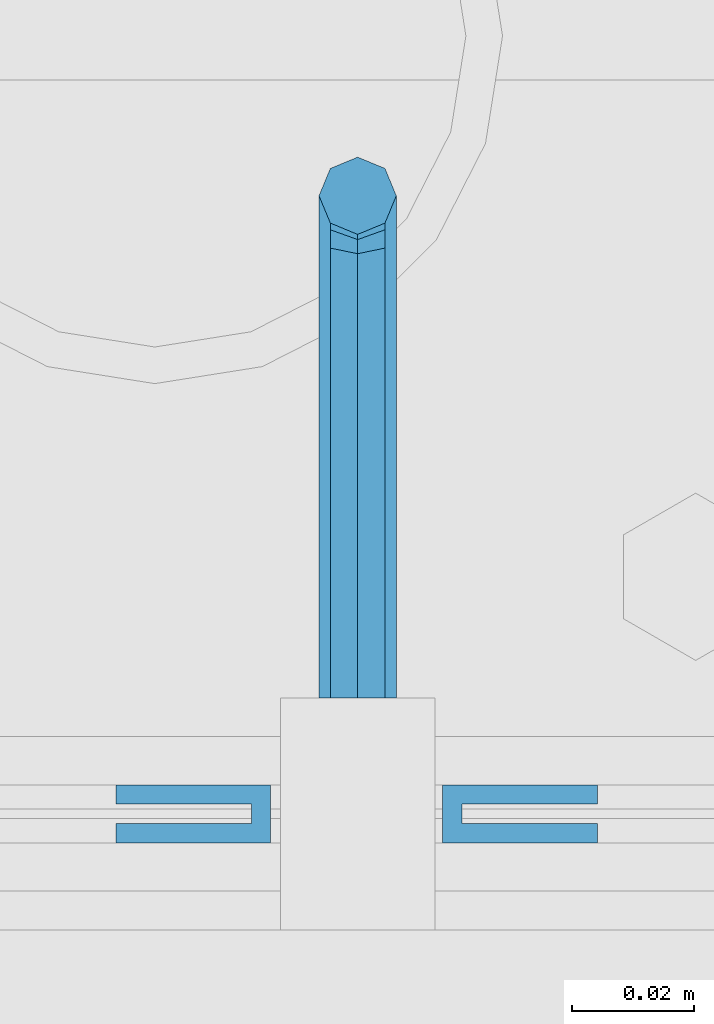
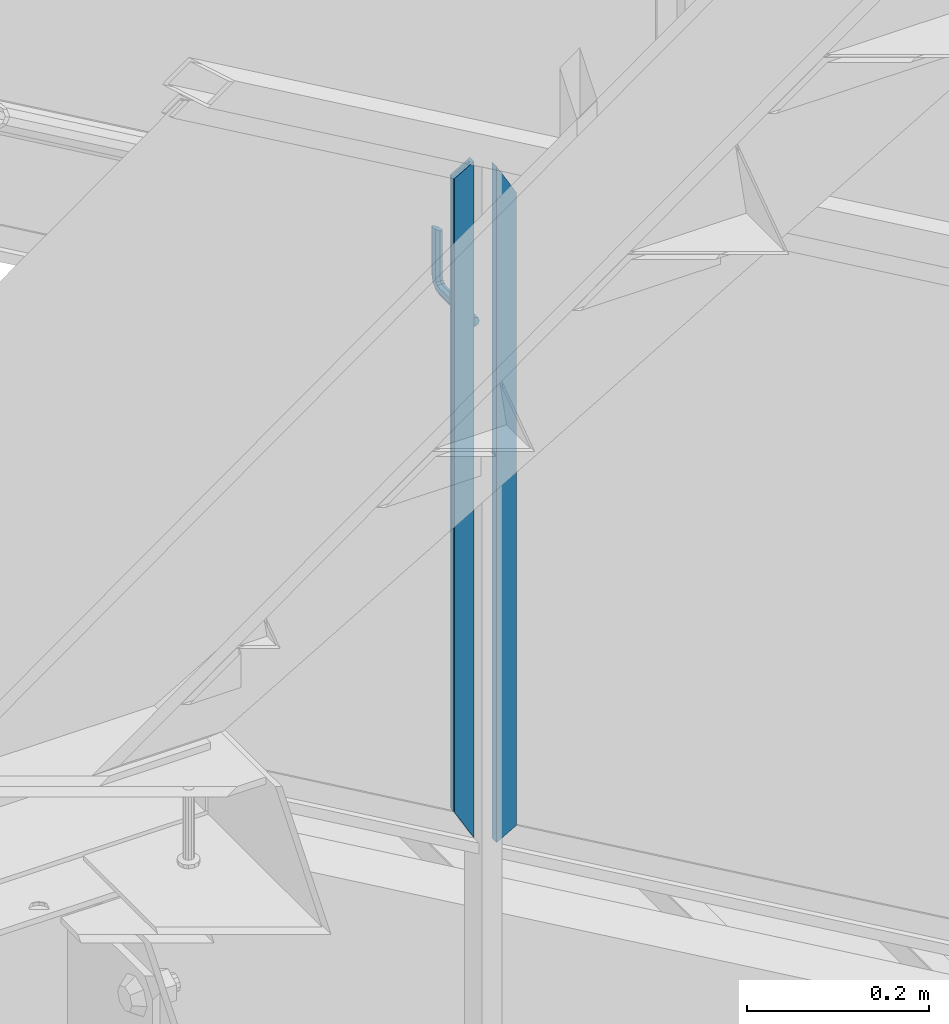
# One storey, part 932 of 1179: 3 beams, 1 element without a shape of its own.
"""IFC2X3 building model written with IfcOpenShell, lengths in millimetres."""

from ifc_helpers import new_model, si_unit, frame, origin_with_axes, place, context, subcontext, project, spatial, faceted_brep, material, type_object, element, aggregate, save


model = new_model("IFC2X3")

# Units and contexts
model_context = context("Model", 3, precision=1e-05, world=origin_with_axes())
body_context = subcontext(model_context, "Body", "Model", "MODEL_VIEW")
ifc_project = project(units=[si_unit("LENGTHUNIT", "METRE", prefix="MILLI"), si_unit("AREAUNIT", "SQUARE_METRE"), si_unit("VOLUMEUNIT", "CUBIC_METRE"), si_unit("MASSUNIT", "GRAM", prefix="KILO"), si_unit("TIMEUNIT", "SECOND"), si_unit("PLANEANGLEUNIT", "RADIAN"), si_unit("SOLIDANGLEUNIT", "STERADIAN"), si_unit("THERMODYNAMICTEMPERATUREUNIT", "DEGREE_CELSIUS"), si_unit("LUMINOUSINTENSITYUNIT", "LUMEN")], contexts=[model_context])

# Site, building, storey
site_placement = place(None, origin_with_axes())
site = spatial("IfcSite", under=ifc_project, at=site_placement, CompositionType="ELEMENT")
building_placement = place(site_placement, origin_with_axes())
building = spatial("IfcBuilding", under=site, at=building_placement, Name="Undefined", CompositionType="ELEMENT")
storey_placement = place(building_placement, origin_with_axes())
storey = spatial("IfcBuildingStorey", under=building, at=storey_placement, Name="Undefined", CompositionType="ELEMENT", Elevation=0.0)

# Assembly, beams
assembly_placement = place(storey_placement, origin_with_axes())
assembly = element("IfcElementAssembly", 1, at=assembly_placement, inside=storey, Name="GUARDRAIL", AssemblyPlace="NOTDEFINED", PredefinedType="RIGID_FRAME")
ifc_material_1 = material(Name="STEEL/BUY-OUT")
beam_type_1 = type_object("IfcBeamType", PredefinedType="NOTDEFINED")
beam_1_placement = place(assembly_placement, frame((20569.2374611471, 39677.9751661867, 4190.68543024958), z_axis=(0.0, 0.0, -1.0), x_axis=(1.0, 0.0, 0.0)))
beam_1 = element("IfcBeam", 2, at=beam_1_placement, type_object=beam_type_1, material=ifc_material_1, Name="U-EDGE", context=body_context, shape_type="Brep", body=[
    faceted_brep([(0.0, 1.58750000000146, 410.762302941614), (25.400000000016, 1.58750000000146, 454.819), (25.400000000016, 1.58750000000146, -454.819), (0.0, 1.58750000000146, -440.175144311391), (0.0, -1.58750000000146, 410.762302941614), (0.0, -1.58750000000146, -440.175144311391), (22.2250000000131, -1.58750000000146, 449.311912867583), (22.2250000000131, -1.58750000000146, -452.988518038564), (22.2250000000131, -4.76249999999709, 449.311912867583), (22.2250000000131, -4.76249999999709, -452.988518038564), (2.91038304567337e-11, -4.76249999999709, 410.762302941664), (2.91038304567337e-11, -4.76249999999709, -440.175144311408), (2.91038304567337e-11, -7.9375, 410.762302941664), (2.91038304567337e-11, -7.9375, -440.175144311408), (25.400000000016, -7.9375, 454.819), (25.400000000016, -7.9375, -454.819)], [[[0, 1, 2, 3]], [[4, 0, 3, 5]], [[6, 4, 5, 7]], [[8, 6, 7, 9]], [[10, 8, 9, 11]], [[12, 10, 11, 13]], [[14, 12, 13, 15]], [[11, 9, 7, 5, 3, 2, 15, 13]], [[1, 14, 15, 2]], [[0, 4, 6, 8, 10, 12, 14, 1]]]),
])
beam_2_placement = place(assembly_placement, frame((20648.3080706334, 39677.9751661867, 4174.31694368419), z_axis=(0.0, 0.0, -1.0), x_axis=(-1.0, 0.0, 0.0)))
beam_2 = element("IfcBeam", 3, at=beam_2_placement, type_object=beam_type_1, material=ifc_material_1, Name="U-EDGE", context=body_context, shape_type="Brep", body=[
    faceted_brep([(2.91038304567337e-11, 7.9375, 440.175302877862), (25.3999999999687, 7.9375, 454.819), (25.400000000016, 7.9375, -454.819), (2.91038304567337e-11, 7.9375, -410.76229705665), (2.91038304567337e-11, 4.76249999999709, 440.175302877862), (2.91038304567337e-11, 4.76249999999709, -410.76229705665), (22.2250000000131, 4.76249999999709, 452.988538277322), (22.2250000000131, 4.76249999999709, -449.311912132071), (22.2250000000131, 1.58750000000146, 452.988538277322), (22.2250000000131, 1.58750000000146, -449.311912132071), (0.0, 1.58750000000146, 440.175302877845), (0.0, 1.58750000000146, -410.7622970566), (0.0, -1.58750000000146, 440.175302877845), (0.0, -1.58750000000146, -410.7622970566), (25.3999999999687, -1.58750000000146, 454.819), (25.400000000016, -1.58750000000146, -454.819)], [[[0, 1, 2, 3]], [[4, 0, 3, 5]], [[6, 4, 5, 7]], [[8, 6, 7, 9]], [[10, 8, 9, 11]], [[12, 10, 11, 13]], [[14, 12, 13, 15]], [[11, 9, 7, 5, 3, 2, 15, 13]], [[1, 14, 15, 2]], [[0, 4, 6, 8, 10, 12, 14, 1]]]),
])
ifc_material_2 = material(Name="STEEL/A36")
beam_type_2 = type_object("IfcBeamType", PredefinedType="NOTDEFINED")
beam_3_placement = place(assembly_placement, frame((20608.9249611471, 39700.2000007745, 4410.06959855291), z_axis=(0.0, 0.0, 1.0), x_axis=(0.0, 1.0, 0.0)))
beam_3 = element("IfcBeam", 4, at=beam_3_placement, type_object=beam_type_2, material=ifc_material_2, Name="BRACKET", context=body_context, shape_type="Brep", body=[
    faceted_brep([(0.0, 0.0, 6.34999999999991), (0.0, -4.49012806053361, 4.49012806053452), (69.849999425729, -4.49012806053361, 4.49012806053452), (69.849999425729, 0.0, 6.34999999999991), (0.0, 4.49012806053361, 4.49012806053452), (69.849999425729, 4.49012806053361, 4.49012806053452), (0.0, 6.34999999999854, 0.0), (69.849999425729, 6.34999999999854, 0.0), (0.0, 4.49012806053361, -4.49012806053452), (69.849999425729, 4.49012806053361, -4.49012806053452), (0.0, 0.0, -6.34999999999991), (69.849999425729, 0.0, -6.34999999999991), (0.0, -4.49012806053361, -4.49012806053452), (69.849999425729, -4.49012806053361, -4.49012806053452), (0.0, -6.34999999999854, 0.0), (69.849999425729, -6.34999999999854, 0.0), (76.1999993303689, -6.34999999999854, 1.70147734638658), (73.9549353000984, -4.49012806053361, 5.59004231305425), (73.024999330366, 0.0, 7.20073866041639), (73.9549353000984, 4.49012806053361, 5.59004231305425), (76.1999993303689, 6.34999999999854, 1.70147734638658), (78.445063360632, 4.49012806053361, -2.18708762028064), (79.3749993303718, 0.0, -3.79778396764323), (78.445063360632, -4.49012806053361, -2.18708762028064), (84.7370868552753, 4.49012806053361, 4.10493587436031), (87.0401272955278, 4.49012806053361, 12.6999998092651), (88.8999992349927, 0.0, 12.6999998092651), (86.3477832026401, 0.0, 3.17499990462693), (80.8485218886053, 6.34999999999854, 6.34999990462893), (82.5499992349942, 6.34999999999854, 12.6999998092651), (76.9599569219426, 4.49012806053361, 8.59506393489755), (78.0598711744606, 4.49012806053361, 12.6999998092651), (75.3492605745778, 0.0, 9.52499990463093), (76.1999992349956, 0.0, 12.6999998092651), (76.9599569219426, -4.49012806053361, 8.59506393489755), (78.0598711744606, -4.49012806053361, 12.6999998092651), (80.8485218886053, -6.34999999999854, 6.34999990462893), (82.5499992349942, -6.34999999999854, 12.6999998092651), (84.7370868552753, -4.49012806053361, 4.10493587436031), (87.0401272955278, -4.49012806053361, 12.6999998092651), (88.8999992349927, 0.0, 76.2000000000003), (87.0401272955278, -4.49012806053361, 73.5797637174637), (82.5499992349942, -6.34999999999854, 72.4944263126154), (78.0598711744606, -4.49012806053361, 73.5797637174637), (76.1999992349956, 0.0, 76.2000000000003), (78.0598711744606, 4.49012806053361, 78.8202362825368), (82.5499992349942, 6.34999999999854, 79.8943188022276), (87.0401272955278, 4.49012806053361, 78.8202362825368)], [[[0, 1, 2, 3]], [[4, 0, 3, 5]], [[6, 4, 5, 7]], [[8, 6, 7, 9]], [[10, 8, 9, 11]], [[12, 10, 11, 13]], [[1, 0, 4, 6, 8, 10, 12, 14]], [[1, 14, 15, 2]], [[14, 12, 13, 15]], [[2, 15, 16, 17]], [[3, 2, 17, 18]], [[5, 3, 18, 19]], [[7, 5, 19, 20]], [[9, 7, 20, 21]], [[11, 9, 21, 22]], [[13, 11, 22, 23]], [[24, 25, 26, 27]], [[28, 29, 25, 24]], [[30, 31, 29, 28]], [[32, 33, 31, 30]], [[34, 35, 33, 32]], [[36, 37, 35, 34]], [[38, 39, 37, 36]], [[27, 26, 39, 38]], [[22, 27, 38, 23]], [[21, 24, 27, 22]], [[20, 28, 24, 21]], [[19, 30, 28, 20]], [[18, 32, 30, 19]], [[17, 34, 32, 18]], [[16, 36, 34, 17]], [[23, 38, 36, 16]], [[15, 13, 23, 16]], [[39, 26, 40, 41]], [[37, 39, 41, 42]], [[35, 37, 42, 43]], [[33, 35, 43, 44]], [[31, 33, 44, 45]], [[29, 31, 45, 46]], [[25, 29, 46, 47]], [[26, 25, 47, 40]], [[46, 45, 44, 43, 42, 41, 40, 47]]]),
])
aggregate(assembly, [beam_1, beam_2, beam_3])

save(model, "model.ifc")
